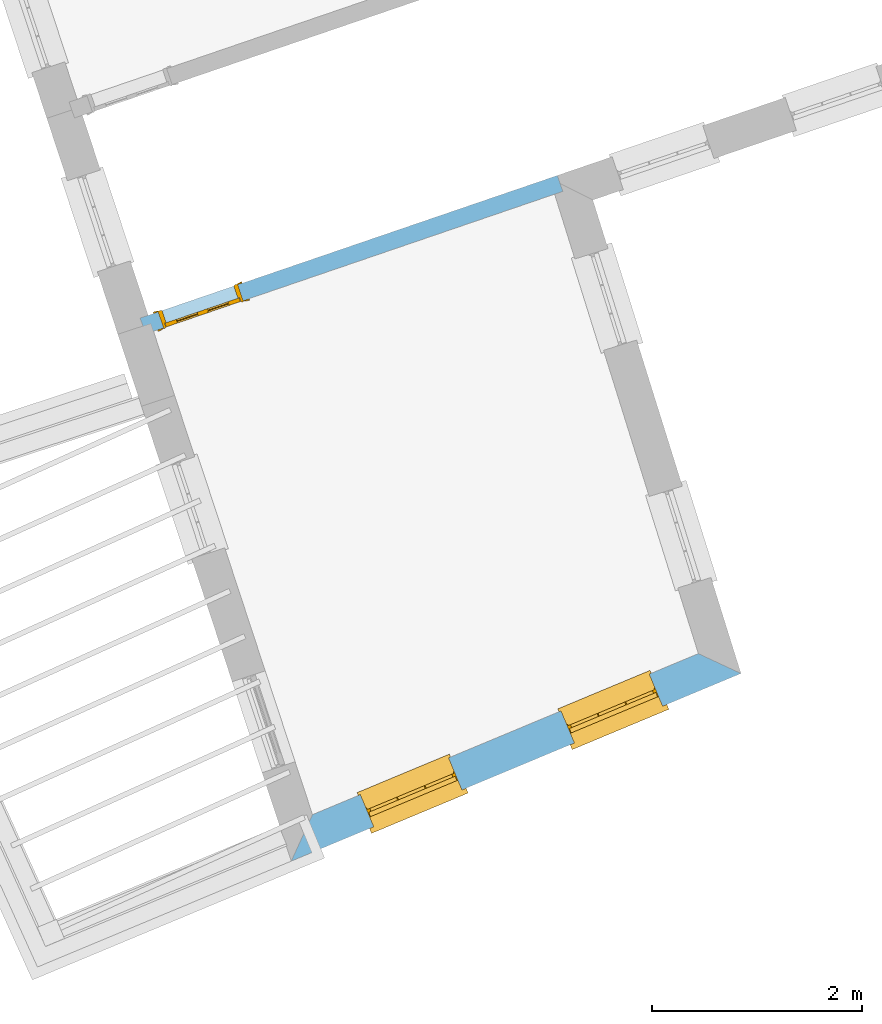
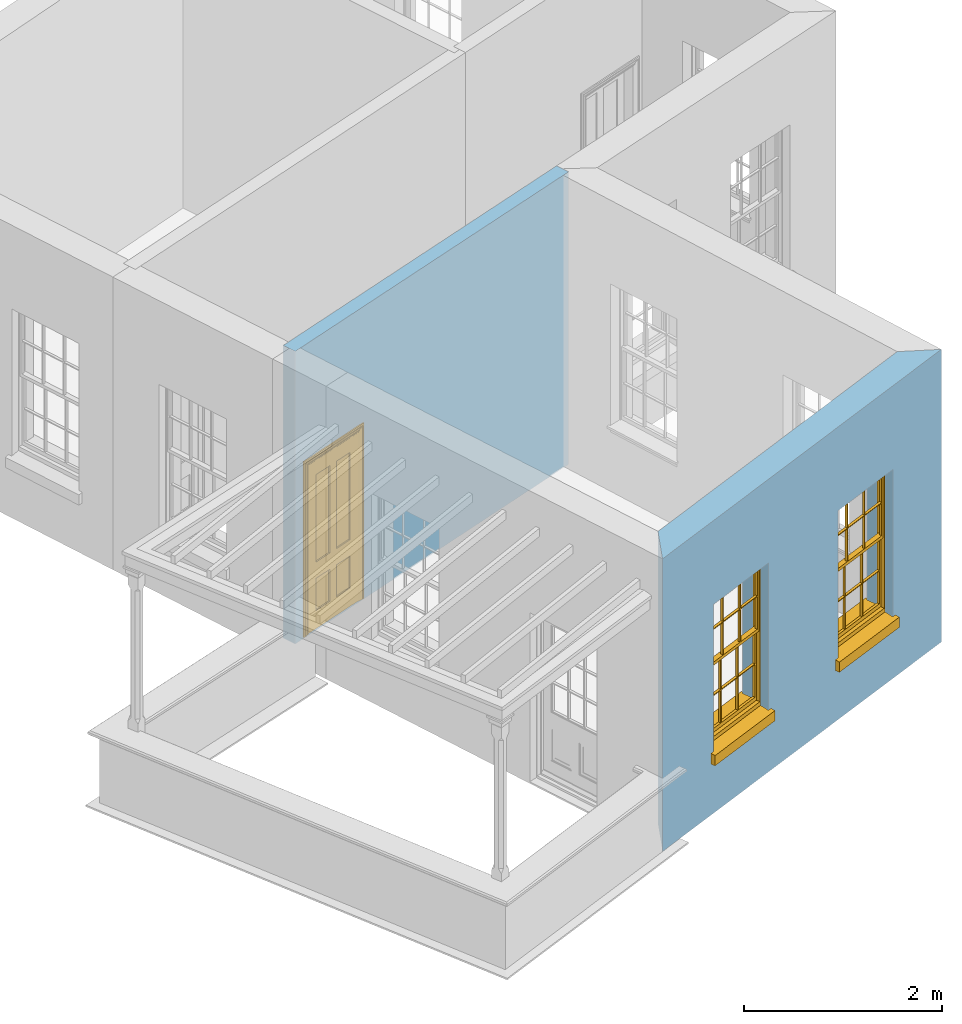
# One storey, part 3 of 10: 2 windows, 1 door, 3 openings, plus 2 elements that do not belong to this part.
"""IFC2X3 building model written with IfcOpenShell, lengths in metres."""

import ifcopenshell
import ifcopenshell.guid

model = None  # the IFC model being written
_history = None  # IfcOwnerHistory: only IFC2X3 demands one
_inside = {}  # id of a spatial element -> (the spatial element, [elements in it])
_under = {}  # id of a project, library or spatial element -> (it, [spatial elements below it])
_declared = {}  # id of a project -> (the project, [libraries it declares])
_typed = {}  # id of a type object -> (the type object, [elements of that type])
_made_of = {}  # id of a material, layer set ... -> (it, [elements and type objects made of it])


def new_model(schema):
    """Start an empty IFC model of exactly this schema.

    Asked for "IFC4X3", IfcOpenShell would pick the latest addendum, in which some entities
    have other attributes; the version numbers below select the first issue.
    IFC2X3 requires an IfcOwnerHistory on every rooted entity: one is made here for all.
    """
    global model, _history
    if schema == "IFC4X3":
        model = ifcopenshell.file(schema_version=(4, 3, 0, 0))
    else:
        model = ifcopenshell.file(schema=schema)
    _inside.clear()
    _under.clear()
    _declared.clear()
    _typed.clear()
    _made_of.clear()
    _history = None
    if model.schema == "IFC2X3":
        org = make("IfcOrganization", Name="unknown")
        user = make(
            "IfcPersonAndOrganization",
            ThePerson=make("IfcPerson", FamilyName="unknown"),
            TheOrganization=org,
        )
        app = make(
            "IfcApplication",
            ApplicationDeveloper=org,
            Version="unknown",
            ApplicationFullName="unknown",
            ApplicationIdentifier="unknown",
        )
        _history = make(
            "IfcOwnerHistory",
            OwningUser=user,
            OwningApplication=app,
            ChangeAction="ADDED",
            CreationDate=0,
        )
    return model


def make(cls, **values):
    """One entity of the class cls with the attributes given. An attribute that is None is left unset."""
    return model.create_entity(
        cls, **{name: value for name, value in values.items() if value is not None}
    )


def rooted(cls, **values):
    """An entity with a GlobalId (a new one), such as an element, a storey or a relation."""
    return make(cls, GlobalId=ifcopenshell.guid.new(), OwnerHistory=_history, **values)


def si_unit(unit_type, name, prefix=None):
    """IfcSIUnit, for example si_unit("LENGTHUNIT", "METRE", prefix="MILLI")."""
    return make("IfcSIUnit", UnitType=unit_type, Prefix=prefix, Name=name)


def assignment(units):
    """IfcUnitAssignment: the units of a project."""
    return None if units is None else make("IfcUnitAssignment", Units=units)


def point(xyz):
    """IfcCartesianPoint."""
    return None if xyz is None else make("IfcCartesianPoint", Coordinates=xyz)


def direction(xyz):
    """IfcDirection."""
    return None if xyz is None else make("IfcDirection", DirectionRatios=xyz)


def frame(location, z_axis=None, x_axis=None):
    """IfcAxis2Placement3D, a coordinate frame: its origin and axes. An axis left out is left unset."""
    return make(
        "IfcAxis2Placement3D",
        Location=point(location),
        Axis=direction(z_axis),
        RefDirection=direction(x_axis),
    )


def origin():
    """The frame at (0, 0, 0) with its axes left unset."""
    return frame((0.0, 0.0, 0.0))


def place(relative_to, where):
    """IfcLocalPlacement: puts the frame where relative to a parent placement (None: the world)."""
    return make(
        "IfcLocalPlacement", PlacementRelTo=relative_to, RelativePlacement=where
    )


def context(
    kind, dimensions, precision=None, world=None, true_north=None, identifier=None
):
    """IfcGeometricRepresentationContext, for example the 3D "Model" context."""
    return make(
        "IfcGeometricRepresentationContext",
        ContextIdentifier=identifier,
        ContextType=kind,
        CoordinateSpaceDimension=dimensions,
        Precision=precision,
        WorldCoordinateSystem=world,
        TrueNorth=true_north,
    )


def subcontext(parent, identifier, kind, view, scale=None):
    """IfcGeometricRepresentationSubContext, for example "Body" below "Model"."""
    return make(
        "IfcGeometricRepresentationSubContext",
        ContextIdentifier=identifier,
        ContextType=kind,
        ParentContext=parent,
        TargetScale=scale,
        TargetView=view,
    )


def project(units=None, contexts=None):
    """IfcProject with its units and contexts."""
    return rooted(
        "IfcProject",
        Name="project",
        RepresentationContexts=contexts,
        UnitsInContext=assignment(units),
    )


def spatial(cls, under=None, at=None, **own):
    """A site, building, storey or space (cls), placed at a placement, below another one or the project."""
    s = rooted(cls, ObjectPlacement=at, **own)
    if under is not None:
        _under.setdefault(under.id(), (under, []))[1].append(s)
    return s


def polyline(points):
    """IfcPolyline through the points."""
    return make("IfcPolyline", Points=[point(p) for p in points])


def outline(outer, holes=None, kind="AREA"):
    """IfcArbitraryClosedProfileDef: a profile drawn as a closed curve; with holes, ...WithVoids."""
    if holes is None:
        return make("IfcArbitraryClosedProfileDef", ProfileType=kind, OuterCurve=outer)
    return make(
        "IfcArbitraryProfileDefWithVoids",
        ProfileType=kind,
        OuterCurve=outer,
        InnerCurves=holes,
    )


def extrude(swept, where, along, depth):
    """IfcExtrudedAreaSolid: the profile swept, set in the frame where, extruded along a direction by depth."""
    return make(
        "IfcExtrudedAreaSolid",
        SweptArea=swept,
        Position=where,
        ExtrudedDirection=direction(along),
        Depth=depth,
    )


def faces_of(points, faces, orient=None, outer=None):
    """IfcFace entities. A face is a list of loops; a loop is a list of indices into points, from 0.

    orient and outer hold one flag for each loop. By default every Orientation is true, the
    first loop of a face is its IfcFaceOuterBound and the others are IfcFaceBound.
    """
    made = []
    for i, loops in enumerate(faces):
        bounds = []
        for j, loop in enumerate(loops):
            is_outer = j == 0 if outer is None else outer[i][j]
            bounds.append(
                make(
                    "IfcFaceOuterBound" if is_outer else "IfcFaceBound",
                    Bound=make("IfcPolyLoop", Polygon=[points[k] for k in loop]),
                    Orientation=True if orient is None else orient[i][j],
                )
            )
        made.append(make("IfcFace", Bounds=bounds))
    return made


def faceted_brep(points, faces, orient=None, outer=None, voids=None):
    """IfcFacetedBrep: a solid bounded by flat faces; with voids (closed shells), ...WithVoids."""
    shared = [point(p) for p in points]
    hull = make("IfcClosedShell", CfsFaces=faces_of(shared, faces, orient, outer))
    if voids is None:
        return make("IfcFacetedBrep", Outer=hull)
    return make(
        "IfcFacetedBrepWithVoids",
        Outer=hull,
        Voids=[
            make(cls, CfsFaces=faces_of(shared, fs, o, b)) for cls, fs, o, b in voids
        ],
    )


def shape(context_of_items, identifier, shape_type, items):
    """IfcShapeRepresentation: the items that make up one representation, for example the "Body"."""
    return make(
        "IfcShapeRepresentation",
        ContextOfItems=context_of_items,
        RepresentationIdentifier=identifier,
        RepresentationType=shape_type,
        Items=items,
    )


def material(Name=None, Category=None):
    """IfcMaterial."""
    return make("IfcMaterial", Name=Name, Category=Category)


def layer(
    of_material, thickness, ventilated=None, Name=None, Category=None, Priority=None
):
    """IfcMaterialLayer: one layer of a wall or slab, of a material (None: an air gap)."""
    return make(
        "IfcMaterialLayer",
        Material=of_material,
        LayerThickness=thickness,
        IsVentilated=ventilated,
        Name=Name,
        Category=Category,
        Priority=Priority,
    )


def layer_set(layers, Name=None):
    """IfcMaterialLayerSet."""
    return make("IfcMaterialLayerSet", MaterialLayers=layers, LayerSetName=Name)


def layer_usage(for_layer_set, set_direction, sense, offset, extent=None):
    """IfcMaterialLayerSetUsage: how a layer set lies in its element."""
    return make(
        "IfcMaterialLayerSetUsage",
        ForLayerSet=for_layer_set,
        LayerSetDirection=set_direction,
        DirectionSense=sense,
        OffsetFromReferenceLine=offset,
        ReferenceExtent=extent,
    )


def made_of(thing, what):
    """Note that an element or type object is made of a material, layer set ...; save() writes the relation."""
    if what is not None:
        _made_of.setdefault(what.id(), (what, []))[1].append(thing)
    return thing


def element(
    cls,
    number,
    at=None,
    inside=None,
    cuts=None,
    type_object=None,
    material=None,
    context=None,
    identifier="Body",
    shape_type=None,
    held_by="IfcProductDefinitionShape",
    body=None,
    shapes=None,
    **own,
):
    """One element of the class cls, such as IfcWall. Its Tag is "e" and its number.

    at: its placement. inside: the storey or other place that contains it. cuts: it is an
    opening in that element (IfcRelVoidsElement). A single representation is given by context,
    identifier, shape_type and body (its items); several are given by shapes. held_by: the class
    of the entity that holds the representations. save() writes the other relations.
    """
    e = rooted(cls, Tag="e%d" % number, ObjectPlacement=at, **own)
    if body is not None:
        shapes = [shape(context, identifier, shape_type, body)]
    if shapes is not None:
        e.Representation = make(held_by, Representations=shapes)
    if inside is not None:
        _inside.setdefault(inside.id(), (inside, []))[1].append(e)
    if cuts is not None:
        rooted(
            "IfcRelVoidsElement", RelatingBuildingElement=cuts, RelatedOpeningElement=e
        )
    if type_object is not None:
        _typed.setdefault(type_object.id(), (type_object, []))[1].append(e)
    return made_of(e, material)


def fill(opening, filler):
    """IfcRelFillsElement: the door or window that sits in an opening."""
    return rooted(
        "IfcRelFillsElement",
        RelatingOpeningElement=opening,
        RelatedBuildingElement=filler,
    )


def aggregate(whole, parts):
    """IfcRelAggregates: a whole, such as a stair, and the parts it consists of."""
    return rooted("IfcRelAggregates", RelatingObject=whole, RelatedObjects=parts)


def save(model, path):
    """Write the relations noted so far, then the file.

    IfcRelAggregates (storeys below a building ...), IfcRelContainedInSpatialStructure (elements
    in a storey), IfcRelDefinesByType, IfcRelAssociatesMaterial and IfcRelDeclares: one each for
    every whole, place, type object, material and project.
    """
    for whole, parts in _under.values():
        aggregate(whole, parts)
    for where, things in _inside.values():
        rooted(
            "IfcRelContainedInSpatialStructure",
            RelatedElements=things,
            RelatingStructure=where,
        )
    for kind, things in _typed.values():
        rooted("IfcRelDefinesByType", RelatedObjects=things, RelatingType=kind)
    for what, things in _made_of.values():
        rooted("IfcRelAssociatesMaterial", RelatedObjects=things, RelatingMaterial=what)
    for by, libraries in _declared.values():
        rooted("IfcRelDeclares", RelatingContext=by, RelatedDefinitions=libraries)
    model.write(path)


model = new_model("IFC2X3")

# Units and contexts
model_context = context("Model", 3, world=origin())
body_context = subcontext(model_context, "Body", "Model", "MODEL_VIEW")
ifc_project = project(units=[si_unit("PLANEANGLEUNIT", "RADIAN"), si_unit("MASSUNIT", "GRAM", prefix="KILO"), si_unit("FORCEUNIT", "NEWTON", prefix="KILO"), si_unit("LENGTHUNIT", "METRE")], contexts=[model_context])

# Site, building, storey
site_placement = place(None, origin())
site = spatial("IfcSite", under=ifc_project, at=site_placement, CompositionType="ELEMENT")
building_placement = place(None, origin())
building = spatial("IfcBuilding", under=site, at=building_placement, Name="Building plot-2", CompositionType="ELEMENT")
storey_placement = place(None, frame((0.0, 0.0, 4.6)))
storey = spatial("IfcBuildingStorey", under=building, at=storey_placement, Name="Floor 1", CompositionType="ELEMENT", Elevation=4.6)

# Wall, openings, windows
ifc_material_1 = material(Name="Masonry")
ifc_layer_1 = layer(ifc_material_1, 0.33, ventilated=False)
ifc_layer_set_1 = layer_set([ifc_layer_1], Name="My Wall")
ifc_layer_usage_1 = layer_usage(ifc_layer_set_1, "AXIS2", "NEGATIVE", 0.08)
wall_1_placement = place(storey_placement, origin())
wall_1 = element("IfcWallStandardCase", 1, at=wall_1_placement, inside=storey, material=ifc_layer_usage_1, Name="exterior", context=body_context, shape_type="SweptSolid", body=[
    extrude(outline(polyline([(30.9770364314834, 26.681595071692), (30.7750053905993, 26.2397204137535), (35.0482793359076, 28.0227845246247), (34.6434756954392, 28.211451652365), (30.9770364314834, 26.681595071692)])), origin(), (0.0, 0.0, 1.0), 3.6),
])
opening_1_placement = place(storey_placement, frame((0.0, 0.0, 0.75)))
opening_1 = element("IfcOpeningElement", 2, at=opening_1_placement, cuts=wall_1, Name="Opening", ObjectType="Opening", context=body_context, shape_type="SweptSolid", body=[
    extrude(outline(polyline([(31.5578056947478, 26.5663512701344), (32.3976288299351, 26.9167754439639), (32.2705519317332, 27.2213266907901), (31.4307287965459, 26.8709025169606), (31.5578056947478, 26.5663512701344)])), origin(), (0.0, 0.0, 1.0), 1.82),
])
opening_2_placement = place(storey_placement, frame((0.0, 0.0, 0.75)))
opening_2 = element("IfcOpeningElement", 3, at=opening_2_placement, cuts=wall_1, Name="Opening", ObjectType="Opening", context=body_context, shape_type="SweptSolid", body=[
    extrude(outline(polyline([(33.4645810456775, 27.3619713823131), (34.3044041808648, 27.7123955561426), (34.1773272826629, 28.0169468029688), (33.3375041474755, 27.6665226291393), (33.4645810456775, 27.3619713823131)])), origin(), (0.0, 0.0, 1.0), 1.82),
])
window_1_placement = place(storey_placement, frame((31.4615353173221, 26.7970719116694, 0.75), z_axis=(0.0, 0.0, 1.0), x_axis=(0.839823135187348, 0.350424173829513, 0.0)))
window_1 = element("IfcWindow", 4, at=window_1_placement, inside=storey, Name="bedroom outside window", OverallHeight=1.82, OverallWidth=0.91, context=body_context, shape_type="Brep", held_by="IfcProductRepresentation", body=[
    faceted_brep([(0.033125, -0.105, 0.975209), (0.01, -0.105, 0.975209), (0.033125, -0.105, 1.376042), (0.876875, -0.105, 0.975209), (0.876875, -0.105, 1.376042), (0.9, -0.105, 0.975209), (0.876875, -0.105, 1.386042), (0.876875, -0.105, 1.786875), (0.9, -0.105, 1.81), (0.033125, -0.105, 1.786875), (0.033125, -0.105, 1.386042), (0.01, -0.105, 1.81), (0.876875, -0.135, 1.376042), (0.876875, -0.135, 0.975209), (0.9, -0.135, 0.937083), (0.033125, -0.135, 1.786875), (0.01, -0.135, 1.81), (0.033125, -0.135, 1.386042), (0.01, -0.135, 0.937083), (0.033125, -0.135, 0.975209), (0.033125, -0.135, 1.376042), (0.876875, -0.135, 1.786875), (0.876875, -0.135, 1.386042), (0.9, -0.135, 1.81), (0.033125, -0.105, 0.937083), (0.01, -0.105, 0.937083), (0.033125, -0.105, 0.53625), (0.876875, -0.105, 0.937083), (0.876875, -0.105, 0.53625), (0.9, -0.105, 0.937083), (0.876875, -0.105, 0.52625), (0.876875, -0.105, 0.125417), (0.9, -0.105, 0.077167), (0.033125, -0.105, 0.125417), (0.033125, -0.105, 0.52625), (0.01, -0.105, 0.077167), (-0.0425, -0.25, 0.01), (-0.0425, -0.3, 0.001667), (0.0, -0.25, 0.01), (0.9525, -0.25, 0.01), (0.91, -0.25, 0.01), (0.9525, -0.3, 0.001667), (-0.02, 0.08, 0.077167), (0.0, 0.08, 0.077167), (-0.02, 0.11, 0.077167), (0.0, -0.06, 0.077167), (0.01, -0.06, 0.077167), (0.91, -0.06, 0.077167), (0.91, 0.08, 0.077167), (0.9, -0.06, 0.077167), (0.93, 0.08, 0.077167), (0.93, 0.11, 0.077167), (0.01, -0.075, 0.975209), (0.9, -0.075, 0.975209), (0.876875, -0.075, 0.125417), (0.876875, -0.075, 0.52625), (0.9, -0.075, 0.077167), (0.876875, -0.075, 0.53625), (0.876875, -0.075, 0.937083), (0.033125, -0.075, 0.125417), (0.01, -0.075, 0.077167), (0.033125, -0.075, 0.52625), (0.033125, -0.075, 0.937083), (0.033125, -0.075, 0.53625), (-0.02, 0.08, 0.052167), (-0.02, 0.11, 0.052167), (0.93, 0.11, 0.052167), (0.93, 0.08, 0.052167), (0.91, 0.08, 0.052167), (0.0, 0.08, 0.052167), (0.91, -0.15, 0.026667), (0.0, -0.15, 0.026667), (-0.0425, -0.3, -0.123333), (0.9525, -0.3, -0.123333), (-0.0425, -0.25, -0.123333), (0.9525, -0.25, -0.123333), (0.01, -0.06, 1.81), (0.9, -0.06, 1.81), (0.0, -0.06, 1.82), (0.91, -0.06, 1.82), (0.01, -0.15, 0.077167), (0.9, -0.15, 0.077167), (0.592292, -0.105, 0.125417), (0.592292, -0.075, 0.125417), (0.317708, -0.075, 0.125417), (0.317708, -0.105, 0.125417), (0.592292, -0.105, 0.53625), (0.317708, -0.105, 0.53625), (0.317708, -0.105, 0.52625), (0.592292, -0.105, 0.52625), (0.592292, -0.075, 0.53625), (0.317708, -0.075, 0.53625), (0.592292, -0.135, 1.386042), (0.592292, -0.105, 1.386042), (0.317708, -0.105, 1.386042), (0.317708, -0.135, 1.386042), (0.317708, -0.135, 1.376042), (0.592292, -0.135, 1.376042), (0.317708, -0.105, 1.376042), (0.592292, -0.105, 1.376042), (0.602292, -0.135, 1.376042), (0.592292, -0.135, 0.975209), (0.602292, -0.135, 0.975209), (0.602292, -0.105, 0.975209), (0.592292, -0.105, 0.975209), (0.602292, -0.105, 1.376042), (0.602292, -0.075, 0.53625), (0.602292, -0.105, 0.53625), (0.317708, -0.075, 0.52625), (0.307708, -0.075, 0.125417), (0.307708, -0.075, 0.52625), (0.602292, -0.075, 0.52625), (0.602292, -0.075, 0.125417), (0.592292, -0.075, 0.52625), (0.307708, -0.075, 0.53625), (0.317708, -0.075, 0.937083), (0.307708, -0.075, 0.937083), (0.602292, -0.075, 0.937083), (0.592292, -0.075, 0.937083), (0.307708, -0.105, 0.52625), (0.307708, -0.105, 0.125417), (0.307708, -0.105, 0.53625), (0.307708, -0.105, 0.937083), (0.592292, -0.105, 0.937083), (0.317708, -0.105, 0.937083), (0.602292, -0.105, 0.937083), (0.602292, -0.105, 0.52625), (0.602292, -0.105, 0.125417), (0.307708, -0.135, 1.386042), (0.307708, -0.135, 1.376042), (0.307708, -0.135, 0.975209), (0.317708, -0.135, 0.975209), (0.317708, -0.135, 1.786875), (0.307708, -0.135, 1.786875), (0.602292, -0.135, 1.786875), (0.592292, -0.135, 1.786875), (0.602292, -0.135, 1.386042), (0.602292, -0.105, 1.386042), (0.307708, -0.105, 1.386042), (0.307708, -0.105, 1.786875), (0.317708, -0.105, 1.786875), (0.592292, -0.105, 1.786875), (0.602292, -0.105, 1.786875), (0.307708, -0.105, 1.376042), (0.317708, -0.105, 0.975209), (0.307708, -0.105, 0.975209), (0.91, -0.15, 1.82), (0.9, -0.15, 1.81), (0.01, -0.15, 1.81), (0.0, -0.15, 1.82), (0.91, -0.25, 0.0), (0.0, -0.25, 0.0), (0.91, 0.08, 0.0), (0.0, 0.08, 0.0)], [[[0, 1, 2]], [[3, 4, 5]], [[6, 7, 8]], [[9, 10, 11]], [[12, 13, 14]], [[15, 16, 17]], [[18, 19, 20]], [[21, 22, 23]], [[24, 25, 26]], [[27, 28, 29]], [[30, 31, 32]], [[33, 34, 35]], [[14, 27, 29]], [[25, 24, 18]], [[36, 37, 38]], [[39, 40, 41]], [[42, 43, 44]], [[45, 46, 43]], [[47, 48, 49]], [[50, 51, 48]], [[1, 0, 52]], [[5, 53, 3]], [[54, 55, 56]], [[57, 58, 53]], [[59, 60, 61]], [[62, 63, 52]], [[48, 43, 46, 49]], [[51, 44, 43, 48]], [[64, 42, 44, 65]], [[65, 44, 51, 66]], [[66, 51, 50, 67]], [[65, 66, 68, 69]], [[60, 56, 49, 46]], [[70, 71, 38, 40]], [[37, 41, 40, 38]], [[37, 72, 73, 41]], [[74, 75, 73, 72]], [[8, 11, 76, 77]], [[76, 78, 79, 77]], [[32, 35, 80, 81]], [[81, 80, 71, 70]], [[82, 83, 84, 85]], [[86, 87, 88, 89]], [[86, 90, 91, 87]], [[92, 93, 94, 95]], [[92, 95, 96, 97]], [[96, 98, 99, 97]], [[100, 97, 101, 102]], [[103, 104, 99, 105]], [[97, 99, 104, 101]], [[102, 103, 105, 100]], [[28, 57, 106, 107]], [[108, 84, 109, 110]], [[111, 112, 83, 113]], [[114, 110, 61, 63]], [[90, 113, 108, 91]], [[115, 91, 114, 116]], [[117, 106, 90, 118]], [[111, 106, 57, 55]], [[119, 110, 109, 120]], [[34, 61, 110, 119]], [[89, 113, 83, 82]], [[88, 108, 113, 89]], [[85, 84, 108, 88]], [[121, 114, 63, 26]], [[122, 116, 114, 121]], [[123, 118, 90, 86]], [[87, 91, 115, 124]], [[107, 106, 117, 125]], [[126, 111, 55, 30]], [[127, 112, 111, 126]], [[126, 30, 28, 107]], [[88, 119, 120, 85]], [[126, 89, 82, 127]], [[125, 123, 86, 107]], [[121, 26, 34, 119]], [[124, 122, 121, 87]], [[128, 17, 20, 129]], [[96, 129, 130, 131]], [[132, 133, 128, 95]], [[134, 135, 92, 136]], [[100, 12, 22, 136]], [[137, 6, 4, 105]], [[94, 138, 139, 140]], [[137, 93, 141, 142]], [[99, 98, 94, 93]], [[143, 2, 10, 138]], [[144, 145, 143, 98]], [[129, 143, 145, 130]], [[20, 2, 143, 129]], [[131, 144, 98, 96]], [[128, 138, 10, 17]], [[133, 139, 138, 128]], [[135, 141, 93, 92]], [[95, 94, 140, 132]], [[22, 6, 137, 136]], [[136, 137, 142, 134]], [[100, 105, 4, 12]], [[107, 86, 89, 126]], [[106, 111, 113, 90]], [[91, 108, 110, 114]], [[87, 121, 119, 88]], [[97, 100, 136, 92]], [[129, 96, 95, 128]], [[98, 143, 138, 94]], [[105, 99, 93, 137]], [[131, 101, 104, 144]], [[124, 115, 118, 123]], [[132, 140, 141, 135]], [[120, 109, 59, 33]], [[15, 9, 139, 133]], [[134, 142, 7, 21]], [[31, 54, 112, 127]], [[36, 74, 72, 37]], [[39, 41, 73, 75]], [[18, 14, 101, 131]], [[23, 16, 132, 135]], [[83, 56, 60, 84]], [[52, 53, 118, 115]], [[53, 52, 144, 104]], [[11, 8, 141, 140]], [[14, 18, 124, 123]], [[2, 1, 11, 10]], [[8, 5, 4, 6]], [[57, 53, 56, 55]], [[60, 52, 63, 61]], [[26, 25, 35, 34]], [[32, 29, 28, 30]], [[14, 23, 22, 12]], [[18, 20, 17, 16]], [[19, 0, 2, 20]], [[17, 10, 9, 15]], [[12, 4, 3, 13]], [[21, 7, 6, 22]], [[27, 58, 57, 28]], [[30, 55, 54, 31]], [[33, 59, 61, 34]], [[26, 63, 62, 24]], [[5, 8, 77, 53]], [[76, 11, 1, 52]], [[46, 45, 78, 76]], [[49, 77, 79, 47]], [[70, 146, 147, 81]], [[71, 80, 148, 149]], [[19, 130, 145, 0]], [[102, 13, 3, 103]], [[116, 122, 24, 62]], [[29, 32, 81, 14]], [[80, 35, 25, 18]], [[60, 46, 76, 52]], [[77, 49, 56, 53]], [[23, 14, 81, 147]], [[16, 148, 80, 18]], [[35, 85, 120]], [[120, 33, 35]], [[127, 82, 32]], [[32, 31, 127]], [[32, 82, 85, 35]], [[102, 101, 14]], [[14, 13, 102]], [[18, 131, 130]], [[130, 19, 18]], [[134, 21, 23]], [[23, 135, 134]], [[16, 15, 133]], [[133, 132, 16]], [[11, 140, 139]], [[139, 9, 11]], [[142, 141, 8]], [[8, 7, 142]], [[23, 147, 148, 16]], [[146, 149, 148, 147]], [[52, 115, 116]], [[116, 62, 52]], [[118, 53, 117]], [[58, 117, 53]], [[27, 125, 117, 58]], [[56, 83, 112]], [[112, 54, 56]], [[109, 84, 60]], [[60, 59, 109]], [[125, 27, 14]], [[14, 123, 125]], [[122, 124, 18]], [[18, 24, 122]], [[145, 144, 52]], [[52, 0, 145]], [[103, 3, 53]], [[53, 104, 103]], [[79, 78, 149, 146]], [[78, 45, 71, 149]], [[146, 70, 47, 79]], [[150, 75, 74, 151]], [[68, 66, 67]], [[48, 68, 67, 50]], [[69, 64, 65]], [[42, 64, 69, 43]], [[69, 68, 152, 153]], [[70, 68, 48, 47]], [[150, 152, 68, 70]], [[43, 69, 71, 45]], [[69, 153, 151, 71]], [[152, 150, 151, 153]], [[38, 151, 74, 36]], [[71, 151, 38]], [[39, 75, 150, 40]], [[40, 150, 70]]]),
])
fill(opening_1, window_1)
window_2_placement = place(storey_placement, frame((33.3683106682518, 27.5926920238481, 0.75), z_axis=(0.0, 0.0, 1.0), x_axis=(0.839823135187352, 0.350424173829513, 0.0)))
window_2 = element("IfcWindow", 5, at=window_2_placement, inside=storey, Name="bedroom outside window", OverallHeight=1.82, OverallWidth=0.91, context=body_context, shape_type="Brep", held_by="IfcProductRepresentation", body=[
    faceted_brep([(0.033125, -0.105, 0.975209), (0.01, -0.105, 0.975209), (0.033125, -0.105, 1.376042), (0.876875, -0.105, 0.975209), (0.876875, -0.105, 1.376042), (0.9, -0.105, 0.975209), (0.876875, -0.105, 1.386042), (0.876875, -0.105, 1.786875), (0.9, -0.105, 1.81), (0.033125, -0.105, 1.786875), (0.033125, -0.105, 1.386042), (0.01, -0.105, 1.81), (0.876875, -0.135, 1.376042), (0.876875, -0.135, 0.975209), (0.9, -0.135, 0.937083), (0.033125, -0.135, 1.786875), (0.01, -0.135, 1.81), (0.033125, -0.135, 1.386042), (0.01, -0.135, 0.937083), (0.033125, -0.135, 0.975209), (0.033125, -0.135, 1.376042), (0.876875, -0.135, 1.786875), (0.876875, -0.135, 1.386042), (0.9, -0.135, 1.81), (0.033125, -0.105, 0.937083), (0.01, -0.105, 0.937083), (0.033125, -0.105, 0.53625), (0.876875, -0.105, 0.937083), (0.876875, -0.105, 0.53625), (0.9, -0.105, 0.937083), (0.876875, -0.105, 0.52625), (0.876875, -0.105, 0.125417), (0.9, -0.105, 0.077167), (0.033125, -0.105, 0.125417), (0.033125, -0.105, 0.52625), (0.01, -0.105, 0.077167), (-0.0425, -0.25, 0.01), (-0.0425, -0.3, 0.001667), (0.0, -0.25, 0.01), (0.9525, -0.25, 0.01), (0.91, -0.25, 0.01), (0.9525, -0.3, 0.001667), (-0.02, 0.08, 0.077167), (0.0, 0.08, 0.077167), (-0.02, 0.11, 0.077167), (0.0, -0.06, 0.077167), (0.01, -0.06, 0.077167), (0.91, -0.06, 0.077167), (0.91, 0.08, 0.077167), (0.9, -0.06, 0.077167), (0.93, 0.08, 0.077167), (0.93, 0.11, 0.077167), (0.01, -0.075, 0.975209), (0.9, -0.075, 0.975209), (0.876875, -0.075, 0.125417), (0.876875, -0.075, 0.52625), (0.9, -0.075, 0.077167), (0.876875, -0.075, 0.53625), (0.876875, -0.075, 0.937083), (0.033125, -0.075, 0.125417), (0.01, -0.075, 0.077167), (0.033125, -0.075, 0.52625), (0.033125, -0.075, 0.937083), (0.033125, -0.075, 0.53625), (-0.02, 0.08, 0.052167), (-0.02, 0.11, 0.052167), (0.93, 0.11, 0.052167), (0.93, 0.08, 0.052167), (0.91, 0.08, 0.052167), (0.0, 0.08, 0.052167), (0.91, -0.15, 0.026667), (0.0, -0.15, 0.026667), (-0.0425, -0.3, -0.123333), (0.9525, -0.3, -0.123333), (-0.0425, -0.25, -0.123333), (0.9525, -0.25, -0.123333), (0.01, -0.06, 1.81), (0.9, -0.06, 1.81), (0.0, -0.06, 1.82), (0.91, -0.06, 1.82), (0.01, -0.15, 0.077167), (0.9, -0.15, 0.077167), (0.592292, -0.105, 0.125417), (0.592292, -0.075, 0.125417), (0.317708, -0.075, 0.125417), (0.317708, -0.105, 0.125417), (0.592292, -0.105, 0.53625), (0.317708, -0.105, 0.53625), (0.317708, -0.105, 0.52625), (0.592292, -0.105, 0.52625), (0.592292, -0.075, 0.53625), (0.317708, -0.075, 0.53625), (0.592292, -0.135, 1.386042), (0.592292, -0.105, 1.386042), (0.317708, -0.105, 1.386042), (0.317708, -0.135, 1.386042), (0.317708, -0.135, 1.376042), (0.592292, -0.135, 1.376042), (0.317708, -0.105, 1.376042), (0.592292, -0.105, 1.376042), (0.602292, -0.135, 1.376042), (0.592292, -0.135, 0.975209), (0.602292, -0.135, 0.975209), (0.602292, -0.105, 0.975209), (0.592292, -0.105, 0.975209), (0.602292, -0.105, 1.376042), (0.602292, -0.075, 0.53625), (0.602292, -0.105, 0.53625), (0.317708, -0.075, 0.52625), (0.307708, -0.075, 0.125417), (0.307708, -0.075, 0.52625), (0.602292, -0.075, 0.52625), (0.602292, -0.075, 0.125417), (0.592292, -0.075, 0.52625), (0.307708, -0.075, 0.53625), (0.317708, -0.075, 0.937083), (0.307708, -0.075, 0.937083), (0.602292, -0.075, 0.937083), (0.592292, -0.075, 0.937083), (0.307708, -0.105, 0.52625), (0.307708, -0.105, 0.125417), (0.307708, -0.105, 0.53625), (0.307708, -0.105, 0.937083), (0.592292, -0.105, 0.937083), (0.317708, -0.105, 0.937083), (0.602292, -0.105, 0.937083), (0.602292, -0.105, 0.52625), (0.602292, -0.105, 0.125417), (0.307708, -0.135, 1.386042), (0.307708, -0.135, 1.376042), (0.307708, -0.135, 0.975209), (0.317708, -0.135, 0.975209), (0.317708, -0.135, 1.786875), (0.307708, -0.135, 1.786875), (0.602292, -0.135, 1.786875), (0.592292, -0.135, 1.786875), (0.602292, -0.135, 1.386042), (0.602292, -0.105, 1.386042), (0.307708, -0.105, 1.386042), (0.307708, -0.105, 1.786875), (0.317708, -0.105, 1.786875), (0.592292, -0.105, 1.786875), (0.602292, -0.105, 1.786875), (0.307708, -0.105, 1.376042), (0.317708, -0.105, 0.975209), (0.307708, -0.105, 0.975209), (0.91, -0.15, 1.82), (0.9, -0.15, 1.81), (0.01, -0.15, 1.81), (0.0, -0.15, 1.82), (0.91, -0.25, 0.0), (0.0, -0.25, 0.0), (0.91, 0.08, 0.0), (0.0, 0.08, 0.0)], [[[0, 1, 2]], [[3, 4, 5]], [[6, 7, 8]], [[9, 10, 11]], [[12, 13, 14]], [[15, 16, 17]], [[18, 19, 20]], [[21, 22, 23]], [[24, 25, 26]], [[27, 28, 29]], [[30, 31, 32]], [[33, 34, 35]], [[14, 27, 29]], [[25, 24, 18]], [[36, 37, 38]], [[39, 40, 41]], [[42, 43, 44]], [[45, 46, 43]], [[47, 48, 49]], [[50, 51, 48]], [[1, 0, 52]], [[5, 53, 3]], [[54, 55, 56]], [[57, 58, 53]], [[59, 60, 61]], [[62, 63, 52]], [[48, 43, 46, 49]], [[51, 44, 43, 48]], [[64, 42, 44, 65]], [[65, 44, 51, 66]], [[66, 51, 50, 67]], [[65, 66, 68, 69]], [[60, 56, 49, 46]], [[70, 71, 38, 40]], [[37, 41, 40, 38]], [[37, 72, 73, 41]], [[74, 75, 73, 72]], [[8, 11, 76, 77]], [[76, 78, 79, 77]], [[32, 35, 80, 81]], [[81, 80, 71, 70]], [[82, 83, 84, 85]], [[86, 87, 88, 89]], [[86, 90, 91, 87]], [[92, 93, 94, 95]], [[92, 95, 96, 97]], [[96, 98, 99, 97]], [[100, 97, 101, 102]], [[103, 104, 99, 105]], [[97, 99, 104, 101]], [[102, 103, 105, 100]], [[28, 57, 106, 107]], [[108, 84, 109, 110]], [[111, 112, 83, 113]], [[114, 110, 61, 63]], [[90, 113, 108, 91]], [[115, 91, 114, 116]], [[117, 106, 90, 118]], [[111, 106, 57, 55]], [[119, 110, 109, 120]], [[34, 61, 110, 119]], [[89, 113, 83, 82]], [[88, 108, 113, 89]], [[85, 84, 108, 88]], [[121, 114, 63, 26]], [[122, 116, 114, 121]], [[123, 118, 90, 86]], [[87, 91, 115, 124]], [[107, 106, 117, 125]], [[126, 111, 55, 30]], [[127, 112, 111, 126]], [[126, 30, 28, 107]], [[88, 119, 120, 85]], [[126, 89, 82, 127]], [[125, 123, 86, 107]], [[121, 26, 34, 119]], [[124, 122, 121, 87]], [[128, 17, 20, 129]], [[96, 129, 130, 131]], [[132, 133, 128, 95]], [[134, 135, 92, 136]], [[100, 12, 22, 136]], [[137, 6, 4, 105]], [[94, 138, 139, 140]], [[137, 93, 141, 142]], [[99, 98, 94, 93]], [[143, 2, 10, 138]], [[144, 145, 143, 98]], [[129, 143, 145, 130]], [[20, 2, 143, 129]], [[131, 144, 98, 96]], [[128, 138, 10, 17]], [[133, 139, 138, 128]], [[135, 141, 93, 92]], [[95, 94, 140, 132]], [[22, 6, 137, 136]], [[136, 137, 142, 134]], [[100, 105, 4, 12]], [[107, 86, 89, 126]], [[106, 111, 113, 90]], [[91, 108, 110, 114]], [[87, 121, 119, 88]], [[97, 100, 136, 92]], [[129, 96, 95, 128]], [[98, 143, 138, 94]], [[105, 99, 93, 137]], [[131, 101, 104, 144]], [[124, 115, 118, 123]], [[132, 140, 141, 135]], [[120, 109, 59, 33]], [[15, 9, 139, 133]], [[134, 142, 7, 21]], [[31, 54, 112, 127]], [[36, 74, 72, 37]], [[39, 41, 73, 75]], [[18, 14, 101, 131]], [[23, 16, 132, 135]], [[83, 56, 60, 84]], [[52, 53, 118, 115]], [[53, 52, 144, 104]], [[11, 8, 141, 140]], [[14, 18, 124, 123]], [[2, 1, 11, 10]], [[8, 5, 4, 6]], [[57, 53, 56, 55]], [[60, 52, 63, 61]], [[26, 25, 35, 34]], [[32, 29, 28, 30]], [[14, 23, 22, 12]], [[18, 20, 17, 16]], [[19, 0, 2, 20]], [[17, 10, 9, 15]], [[12, 4, 3, 13]], [[21, 7, 6, 22]], [[27, 58, 57, 28]], [[30, 55, 54, 31]], [[33, 59, 61, 34]], [[26, 63, 62, 24]], [[5, 8, 77, 53]], [[76, 11, 1, 52]], [[46, 45, 78, 76]], [[49, 77, 79, 47]], [[70, 146, 147, 81]], [[71, 80, 148, 149]], [[19, 130, 145, 0]], [[102, 13, 3, 103]], [[116, 122, 24, 62]], [[29, 32, 81, 14]], [[80, 35, 25, 18]], [[60, 46, 76, 52]], [[77, 49, 56, 53]], [[23, 14, 81, 147]], [[16, 148, 80, 18]], [[35, 85, 120]], [[120, 33, 35]], [[127, 82, 32]], [[32, 31, 127]], [[32, 82, 85, 35]], [[102, 101, 14]], [[14, 13, 102]], [[18, 131, 130]], [[130, 19, 18]], [[134, 21, 23]], [[23, 135, 134]], [[16, 15, 133]], [[133, 132, 16]], [[11, 140, 139]], [[139, 9, 11]], [[142, 141, 8]], [[8, 7, 142]], [[23, 147, 148, 16]], [[146, 149, 148, 147]], [[52, 115, 116]], [[116, 62, 52]], [[118, 53, 117]], [[58, 117, 53]], [[27, 125, 117, 58]], [[56, 83, 112]], [[112, 54, 56]], [[109, 84, 60]], [[60, 59, 109]], [[125, 27, 14]], [[14, 123, 125]], [[122, 124, 18]], [[18, 24, 122]], [[145, 144, 52]], [[52, 0, 145]], [[103, 3, 53]], [[53, 104, 103]], [[79, 78, 149, 146]], [[78, 45, 71, 149]], [[146, 70, 47, 79]], [[150, 75, 74, 151]], [[68, 66, 67]], [[48, 68, 67, 50]], [[69, 64, 65]], [[42, 64, 69, 43]], [[69, 68, 152, 153]], [[70, 68, 48, 47]], [[150, 152, 68, 70]], [[43, 69, 71, 45]], [[69, 153, 151, 71]], [[152, 150, 151, 153]], [[38, 151, 74, 36]], [[71, 151, 38]], [[39, 75, 150, 40]], [[40, 150, 70]]]),
])
fill(opening_2, window_2)

# Wall, opening, door
ifc_material_2 = material(Name="Masonry")
ifc_layer_2 = layer(ifc_material_2, 0.16, ventilated=False)
ifc_layer_set_2 = layer_set([ifc_layer_2], Name="My Wall")
ifc_layer_usage_2 = layer_usage(ifc_layer_set_2, "AXIS2", "NEGATIVE", 0.08)
wall_2_placement = place(storey_placement, origin())
wall_2 = element("IfcWallStandardCase", 6, at=wall_2_placement, inside=storey, material=ifc_layer_usage_2, Name="interior", context=body_context, shape_type="SweptSolid", body=[
    extrude(outline(polyline([(33.3553608937437, 32.6034484371677), (33.3035954596887, 32.7548430864691), (29.3397406893014, 31.3995067937606), (29.3915061233564, 31.2481121444592), (33.3553608937437, 32.6034484371677)])), origin(), (0.0, 0.0, 1.0), 3.6),
])
opening_3_placement = place(storey_placement, frame((0.0, 0.0, 0.0199999999999996)))
opening_3 = element("IfcOpeningElement", 7, at=opening_3_placement, cuts=wall_2, Name="Opening", ObjectType="Opening", context=body_context, shape_type="SweptSolid", body=[
    extrude(outline(polyline([(30.2670329162725, 31.7165700773475), (29.5100596697655, 31.4577429070725), (29.5618251038205, 31.3063482577711), (30.3187983503275, 31.5651754280461), (30.2670329162725, 31.7165700773475)])), origin(), (0.0, 0.0, 1.0), 2.1),
])
door_placement = place(storey_placement, frame((30.2929156333, 31.6408727526968, 0.0199999999999996), z_axis=(0.0, 0.0, 1.0), x_axis=(-0.756973246507059, -0.258827170274998, 0.0)))
door = element("IfcDoor", 8, at=door_placement, inside=storey, Name="bedroom inside door", OverallHeight=2.1, OverallWidth=0.8, context=body_context, shape_type="Brep", held_by="IfcProductRepresentation", body=[
    faceted_brep([(0.773, 0.08, 1.895), (0.66, 0.08, 1.895), (0.66, 0.08, 2.073), (0.773, 0.08, 2.073), (0.773, 0.08, 0.82), (0.66, 0.08, 0.82), (0.45, 0.08, 1.895), (0.45, 0.08, 2.073), (0.773, 0.08, 0.62), (0.66, 0.08, 0.62), (0.66, 0.065, 0.82), (0.66, 0.065, 1.895), (0.45, 0.065, 1.895), (0.35, 0.08, 1.895), (0.35, 0.08, 2.073), (0.773, 0.08, 0.225), (0.66, 0.08, 0.225), (0.45, 0.08, 0.62), (0.45, 0.08, 0.82), (0.45, 0.065, 0.82), (0.35, 0.08, 0.82), (0.14, 0.08, 2.073), (0.14, 0.08, 1.895), (0.773, 0.08, 0.0), (0.66, 0.08, 0.0), (0.66, 0.065, 0.225), (0.66, 0.065, 0.62), (0.45, 0.065, 0.62), (0.35, 0.08, 0.62), (0.35, 0.065, 0.82), (0.35, 0.065, 1.895), (0.14, 0.065, 1.895), (0.027, 0.08, 2.073), (0.027, 0.08, 1.895), (0.773, 0.042, 0.0), (0.66, 0.042, 0.0), (0.45, 0.08, 0.0), (0.45, 0.08, 0.225), (0.45, 0.065, 0.225), (0.35, 0.08, 0.225), (0.14, 0.08, 0.82), (0.14, 0.08, 0.62), (0.14, 0.065, 0.82), (0.027, 0.08, 0.82), (0.773, 0.042, 0.225), (0.66, 0.042, 0.225), (0.45, 0.042, 0.0), (0.35, 0.08, 0.0), (0.35, 0.065, 0.225), (0.35, 0.065, 0.62), (0.14, 0.065, 0.62), (0.027, 0.08, 0.62), (0.773, 0.042, 0.62), (0.66, 0.042, 0.62), (0.45, 0.042, 0.225), (0.35, 0.042, 0.0), (0.14, 0.08, 0.225), (0.14, 0.08, 0.0), (0.14, 0.065, 0.225), (0.027, 0.08, 0.225), (0.773, 0.042, 0.82), (0.66, 0.042, 0.82), (0.66, 0.057, 0.62), (0.66, 0.057, 0.225), (0.45, 0.057, 0.225), (0.35, 0.042, 0.225), (0.14, 0.042, 0.0), (0.027, 0.08, 0.0), (0.773, 0.042, 1.895), (0.66, 0.042, 1.895), (0.45, 0.042, 0.62), (0.45, 0.042, 0.82), (0.45, 0.057, 0.62), (0.35, 0.042, 0.62), (0.14, 0.042, 0.225), (0.027, 0.042, 0.0), (0.773, 0.042, 2.073), (0.66, 0.042, 2.073), (0.66, 0.057, 1.895), (0.66, 0.057, 0.82), (0.45, 0.057, 0.82), (0.35, 0.042, 0.82), (0.35, 0.057, 0.62), (0.35, 0.057, 0.225), (0.14, 0.057, 0.225), (0.027, 0.042, 0.225), (0.45, 0.042, 1.895), (0.45, 0.042, 2.073), (0.45, 0.057, 1.895), (0.35, 0.042, 1.895), (0.14, 0.042, 0.82), (0.14, 0.042, 0.62), (0.14, 0.057, 0.62), (0.027, 0.042, 0.62), (0.35, 0.042, 2.073), (0.35, 0.057, 1.895), (0.35, 0.057, 0.82), (0.14, 0.057, 0.82), (0.027, 0.042, 0.82), (0.14, 0.042, 2.073), (0.14, 0.042, 1.895), (0.14, 0.057, 1.895), (0.027, 0.042, 1.895), (0.027, 0.042, 2.073), (0.02, 0.085, 0.0), (0.005, 0.09, 0.0), (0.005, 0.09, 2.095), (0.02, 0.085, 2.08), (0.02, 0.08, 0.0), (0.0, 0.085, 0.0), (0.0, 0.085, 2.1), (0.795, 0.09, 2.095), (0.78, 0.085, 2.08), (0.02, 0.08, 2.08), (0.0, 0.08, 0.0), (-0.032, 0.095, 0.0), (-0.032, 0.095, 2.132), (0.8, 0.085, 2.1), (0.795, 0.09, 0.0), (0.78, 0.085, 0.0), (0.78, 0.08, 2.08), (0.04, 0.04, 0.0), (0.025, 0.04, 0.0), (0.025, 0.04, 2.075), (0.04, 0.04, 2.06), (-0.04, 0.09, 0.0), (-0.04, 0.09, 2.14), (0.832, 0.095, 2.132), (0.8, 0.085, 0.0), (0.78, 0.08, 0.0), (0.8, 0.08, 0.0), (0.86, 0.08, 0.0), (0.86, 0.08, 2.16), (0.8, 0.08, 2.1), (-0.06, 0.08, 2.16), (0.0, 0.08, 2.1), (-0.06, 0.08, 0.0), (-0.04, 0.095, 0.0), (-0.04, 0.095, 2.14), (0.84, 0.09, 2.14), (0.832, 0.095, 0.0), (0.84, 0.09, 0.0), (0.86, 0.095, 0.0), (0.86, 0.095, 2.16), (-0.06, 0.095, 2.16), (-0.06, 0.095, 0.0), (0.84, 0.095, 0.0), (0.84, 0.095, 2.14), (-0.025, -0.095, 0.0), (-0.025, -0.09, 0.0), (-0.025, -0.09, 2.125), (-0.025, -0.095, 2.125), (-0.017, -0.095, 0.0), (-0.017, -0.095, 2.117), (0.825, -0.09, 2.125), (0.825, -0.095, 2.125), (0.825, -0.095, 0.0), (0.845, -0.095, 0.0), (-0.045, -0.095, 2.145), (-0.045, -0.095, 0.0), (0.845, -0.095, 2.145), (0.015, -0.085, 0.0), (0.015, -0.085, 2.085), (0.817, -0.095, 2.117), (0.825, -0.09, 0.0), (0.845, -0.08, 0.0), (0.845, -0.08, 2.145), (-0.045, -0.08, 2.145), (-0.045, -0.08, 0.0), (0.02, -0.09, 0.0), (0.02, -0.09, 2.08), (0.785, -0.085, 2.085), (0.817, -0.095, 0.0), (0.8, -0.08, 0.0), (0.8, -0.08, 2.1), (0.0, -0.08, 2.1), (0.0, -0.08, 0.0), (0.035, -0.085, 0.0), (0.035, -0.085, 2.065), (0.78, -0.09, 2.08), (0.785, -0.085, 0.0), (0.775, 0.04, 2.075), (0.76, 0.04, 2.06), (0.035, -0.08, 2.065), (0.035, -0.08, 0.0), (0.765, -0.085, 2.065), (0.78, -0.09, 0.0), (0.765, -0.08, 0.0), (0.765, -0.08, 2.065), (0.765, -0.085, 0.0), (0.04, -0.08, 2.06), (0.04, -0.08, 0.0), (0.76, -0.08, 2.06), (0.76, -0.08, 0.0), (0.76, 0.04, 0.0), (0.775, 0.04, 0.0), (0.025, 0.08, 0.0), (0.025, 0.08, 2.075), (0.775, 0.08, 0.0), (0.775, 0.08, 2.075)], [[[0, 1, 2, 3]], [[1, 0, 4, 5]], [[1, 6, 7, 2]], [[8, 9, 5, 4]], [[1, 5, 10, 11]], [[6, 1, 11, 12]], [[6, 13, 14, 7]], [[15, 16, 9, 8]], [[9, 17, 18, 5]], [[5, 18, 19, 10]], [[10, 19, 12, 11]], [[18, 6, 12, 19]], [[18, 20, 13, 6]], [[21, 14, 13, 22]], [[23, 24, 16, 15]], [[9, 16, 25, 26]], [[17, 9, 26, 27]], [[17, 28, 20, 18]], [[13, 20, 29, 30]], [[22, 13, 30, 31]], [[32, 21, 22, 33]], [[34, 35, 24, 23]], [[24, 36, 37, 16]], [[16, 37, 38, 25]], [[25, 38, 27, 26]], [[37, 17, 27, 38]], [[37, 39, 28, 17]], [[40, 20, 28, 41]], [[20, 40, 42, 29]], [[31, 30, 29, 42]], [[40, 22, 31, 42]], [[33, 22, 40, 43]], [[35, 34, 44, 45]], [[35, 46, 36, 24]], [[36, 47, 39, 37]], [[28, 39, 48, 49]], [[41, 28, 49, 50]], [[43, 40, 41, 51]], [[45, 44, 52, 53]], [[46, 35, 45, 54]], [[46, 55, 47, 36]], [[56, 39, 47, 57]], [[39, 56, 58, 48]], [[50, 49, 48, 58]], [[56, 41, 50, 58]], [[51, 41, 56, 59]], [[53, 52, 60, 61]], [[45, 53, 62, 63]], [[54, 45, 63, 64]], [[55, 46, 54, 65]], [[55, 66, 57, 47]], [[59, 56, 57, 67]], [[61, 60, 68, 69]], [[70, 53, 61, 71]], [[53, 70, 72, 62]], [[72, 64, 63, 62]], [[70, 54, 64, 72]], [[65, 54, 70, 73]], [[65, 74, 66, 55]], [[67, 57, 66, 75]], [[69, 68, 76, 77]], [[61, 69, 78, 79]], [[71, 61, 79, 80]], [[73, 70, 71, 81]], [[65, 73, 82, 83]], [[74, 65, 83, 84]], [[74, 85, 75, 66]], [[86, 69, 77, 87]], [[69, 86, 88, 78]], [[88, 80, 79, 78]], [[86, 71, 80, 88]], [[81, 71, 86, 89]], [[73, 81, 90, 91]], [[73, 91, 92, 82]], [[83, 82, 92, 84]], [[91, 74, 84, 92]], [[91, 93, 85, 74]], [[89, 86, 87, 94]], [[81, 89, 95, 96]], [[90, 81, 96, 97]], [[90, 98, 93, 91]], [[94, 99, 100, 89]], [[89, 100, 101, 95]], [[101, 97, 96, 95]], [[100, 90, 97, 101]], [[100, 102, 98, 90]], [[99, 103, 102, 100]], [[32, 103, 99, 21]], [[102, 103, 32, 33]], [[98, 102, 33, 43]], [[21, 99, 94, 14]], [[94, 87, 7, 14]], [[7, 87, 77, 2]], [[76, 3, 2, 77]], [[43, 51, 93, 98]], [[51, 59, 85, 93]], [[67, 75, 85, 59]], [[34, 23, 15, 44]], [[44, 15, 8, 52]], [[52, 8, 4, 60]], [[0, 68, 60, 4]], [[0, 3, 76, 68]], [[104, 105, 106, 107]], [[104, 108, 109, 105]], [[105, 109, 110, 106]], [[107, 106, 111, 112]], [[107, 113, 108, 104]], [[114, 109, 108]], [[109, 115, 116, 110]], [[106, 110, 117, 111]], [[112, 111, 118, 119]], [[113, 107, 112, 120]], [[121, 122, 123, 124]], [[115, 109, 114, 125]], [[115, 125, 126, 116]], [[110, 116, 127, 117]], [[111, 117, 128, 118]], [[118, 128, 129, 119]], [[120, 112, 119, 129]], [[130, 129, 128]], [[130, 131, 132, 133]], [[133, 132, 134, 135]], [[135, 134, 136, 114]], [[136, 125, 114]], [[125, 137, 138, 126]], [[116, 126, 139, 127]], [[117, 127, 140, 128]], [[141, 130, 128, 140]], [[131, 130, 141]], [[131, 142, 143, 132]], [[132, 143, 144, 134]], [[134, 144, 145, 136]], [[137, 125, 136, 145]], [[143, 142, 146]], [[143, 146, 147]], [[137, 145, 144]], [[143, 147, 138]], [[138, 137, 144]], [[143, 138, 144]], [[126, 138, 147, 139]], [[127, 139, 141, 140]], [[142, 131, 141, 146]], [[139, 147, 146, 141]], [[148, 149, 150, 151]], [[149, 152, 153, 150]], [[151, 150, 154, 155]], [[155, 156, 157]], [[158, 159, 148]], [[158, 148, 151]], [[155, 157, 160]], [[158, 151, 155]], [[155, 160, 158]], [[152, 161, 162, 153]], [[150, 153, 163, 154]], [[155, 154, 164, 156]], [[156, 164, 165, 157]], [[157, 165, 166, 160]], [[160, 166, 167, 158]], [[158, 167, 168, 159]], [[161, 169, 170, 162]], [[153, 162, 171, 163]], [[154, 163, 172, 164]], [[165, 164, 173]], [[165, 173, 174, 166]], [[166, 174, 175, 167]], [[167, 175, 176, 168]], [[169, 177, 178, 170]], [[162, 170, 179, 171]], [[163, 171, 180, 172]], [[172, 180, 173, 164]], [[124, 123, 181, 182]], [[183, 178, 177, 184]], [[170, 178, 185, 179]], [[171, 179, 186, 180]], [[187, 173, 180]], [[185, 188, 187, 189]], [[188, 185, 178, 183]], [[179, 185, 189, 186]], [[189, 187, 180, 186]], [[190, 183, 184, 191]], [[192, 188, 183, 190]], [[191, 184, 122, 121]], [[124, 190, 191, 121]], [[193, 187, 188, 192]], [[182, 192, 190, 124]], [[184, 176, 122]], [[194, 195, 187, 193]], [[192, 182, 194, 193]], [[161, 176, 184]], [[114, 108, 122, 176]], [[173, 187, 195]], [[152, 149, 176, 161]], [[169, 161, 184, 177]], [[196, 122, 108]], [[176, 175, 135, 114]], [[173, 195, 129, 130]], [[176, 149, 168]], [[123, 122, 196, 197]], [[196, 108, 113, 197]], [[175, 174, 133, 135]], [[198, 129, 195]], [[133, 174, 173, 130]], [[159, 168, 149, 148]], [[181, 123, 197, 199]], [[197, 113, 120, 199]], [[199, 120, 129, 198]], [[195, 181, 199, 198]], [[195, 194, 182, 181]]]),
])
fill(opening_3, door)

save(model, "model.ifc")
